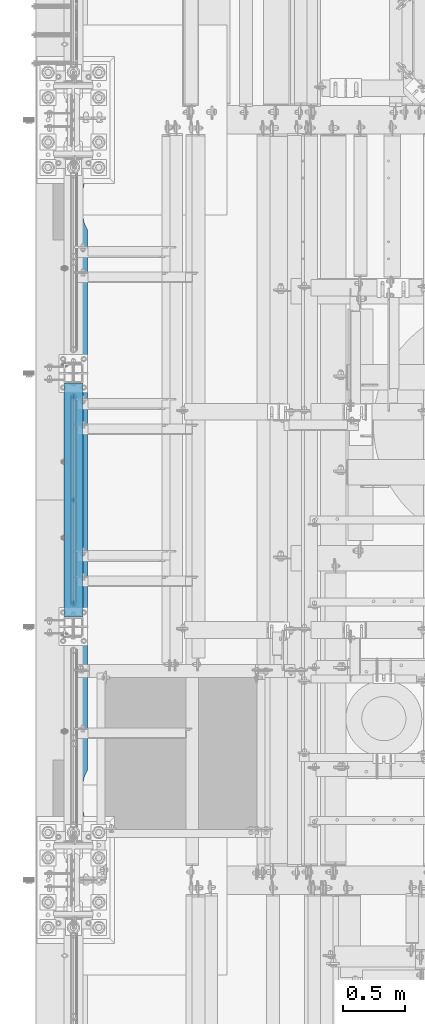
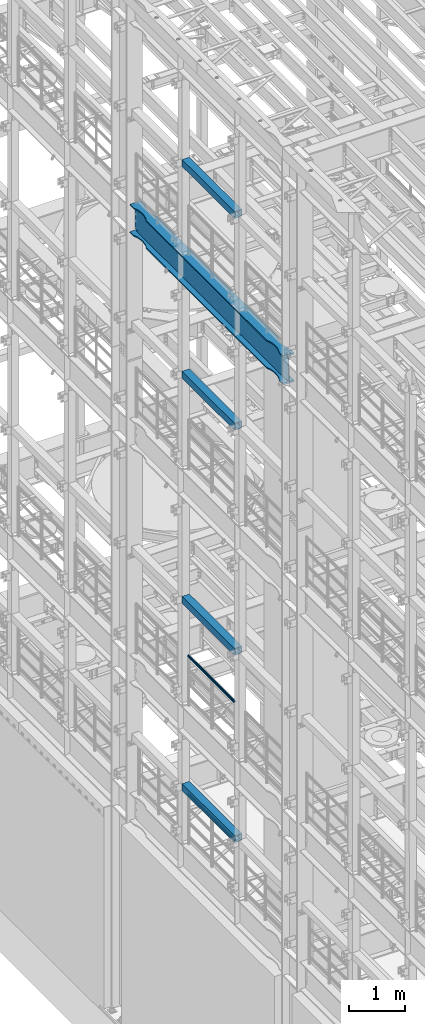
# One storey, part 1020 of 1876: 7 beams, 7 elements without a shape of their own.
"""IFC2X3 building model written with IfcOpenShell, lengths in millimetres."""

from ifc_helpers import new_model, si_unit, frame, origin_with_axes, place, context, subcontext, project, spatial, faceted_brep, material, type_object, element, aggregate, save


model = new_model("IFC2X3")

# Units and contexts
model_context = context("Model", 3, precision=1e-05, world=origin_with_axes())
body_context = subcontext(model_context, "Body", "Model", "MODEL_VIEW")
ifc_project = project(units=[si_unit("LENGTHUNIT", "METRE", prefix="MILLI"), si_unit("AREAUNIT", "SQUARE_METRE"), si_unit("VOLUMEUNIT", "CUBIC_METRE"), si_unit("MASSUNIT", "GRAM", prefix="KILO"), si_unit("TIMEUNIT", "SECOND"), si_unit("PLANEANGLEUNIT", "RADIAN"), si_unit("SOLIDANGLEUNIT", "STERADIAN"), si_unit("THERMODYNAMICTEMPERATUREUNIT", "DEGREE_CELSIUS"), si_unit("LUMINOUSINTENSITYUNIT", "LUMEN")], contexts=[model_context])

# Site, building, storey
site_placement = place(None, origin_with_axes())
site = spatial("IfcSite", under=ifc_project, at=site_placement, CompositionType="ELEMENT")
building_placement = place(site_placement, origin_with_axes())
building = spatial("IfcBuilding", under=site, at=building_placement, Name="Undefined", CompositionType="ELEMENT")
storey_placement = place(building_placement, origin_with_axes())
storey = spatial("IfcBuildingStorey", under=building, at=storey_placement, Name="Undefined", CompositionType="ELEMENT", Elevation=0.0)

# Assembly, beam
assembly_1_placement = place(storey_placement, origin_with_axes())
assembly_1 = element("IfcElementAssembly", 1, at=assembly_1_placement, inside=storey, Name="RAIL", AssemblyPlace="NOTDEFINED", PredefinedType="RIGID_FRAME")
ifc_material_1 = material()
beam_type_1 = type_object("IfcBeamType", Name="PIPE1-1/2SCH40", PredefinedType="NOTDEFINED")
beam_1_placement = place(assembly_1_placement, frame((-1.81898940354586e-12, 3721.1, 9229.725), z_axis=(0.0, 0.0, -1.0), x_axis=(0.0, 1.0, 0.0)))
beam_1 = element("IfcBeam", 2, at=beam_1_placement, type_object=beam_type_1, material=ifc_material_1, Name="RAIL", ObjectType="PIPE1-1/2SCH40", context=body_context, shape_type="Brep", body=[
    faceted_brep([(24.1300000000001, -20.4469999999999, 0.0), (34.3535000000002, -17.7076214311803, 10.2235000000001), (1667.4465, -17.7076214311801, 10.2235000000001), (1677.67, -20.4470000000001, 0.0), (41.8376214311802, -10.2235000000001, 17.7076214311819), (1659.96237856882, -10.2235000000001, 17.7076214311819), (44.5770000000002, 0.0, 20.4470000000001), (1657.223, 0.0, 20.4470000000001), (41.8376214311802, 10.2235000000001, 17.7076214311819), (1659.96237856882, 10.2235000000001, 17.7076214311819), (34.3535000000002, 17.7076214311803, 10.2235000000001), (1667.4465, 17.7076214311801, 10.2235000000001), (24.1300000000001, 20.4469999999999, 0.0), (1677.67, 20.4470000000001, 0.0), (13.9065000000001, 17.7076214311803, -10.2235000000001), (1687.8935, 17.7076214311801, -10.2235000000001), (6.42237856882002, 10.2235000000001, -17.7076214311819), (1695.37762143118, 10.2235000000001, -17.7076214311819), (3.68299999999999, 0.0, -20.4470000000001), (1698.117, 0.0, -20.4470000000001), (6.42237856882002, -10.2235000000001, -17.7076214311819), (1695.37762143118, -10.2235000000001, -17.7076214311819), (13.9065000000001, -17.7076214311803, -10.2235000000001), (1687.8935, -17.7076214311801, -10.2235000000001), (24.1299999999854, -24.1299999999992, 0.0), (12.0650000000064, -20.8971929933177, -12.0649999999987), (1689.735, -20.8971929933186, -12.0649999999987), (1677.67, -24.1300000000001, 0.0), (3.23280700668147, -12.0650000000001, -20.8971929933177), (1698.56719299332, -12.0649999999996, -20.8971929933177), (-1.45519152283669e-11, 0.0, -24.130000000001), (1701.8, 0.0, -24.130000000001), (3.23280700668147, 12.0650000000001, -20.8971929933177), (1698.56719299332, 12.0649999999996, -20.8971929933177), (12.0650000000064, 20.8971929933177, -12.0649999999987), (1689.735, 20.8971929933186, -12.0649999999987), (24.1300000000047, 24.1299999999992, 0.0), (1677.67, 24.1300000000001, 0.0), (36.1949999999997, 20.8971929933184, 12.0649999999987), (1665.605, 20.8971929933186, 12.0649999999987), (45.0271929933187, 12.0650000000001, 20.8971929933177), (1656.77280700668, 12.0649999999996, 20.8971929933177), (48.2600000000002, 0.0, 24.130000000001), (1653.54, 0.0, 24.130000000001), (45.0271929933187, -12.0650000000001, 20.8971929933177), (1656.77280700668, -12.0649999999996, 20.8971929933177), (36.1949999999997, -20.8971929933184, 12.0649999999987), (1665.605, -20.8971929933186, 12.0649999999987)], [[[0, 1, 2, 3]], [[1, 4, 5, 2]], [[4, 6, 7, 5]], [[6, 8, 9, 7]], [[8, 10, 11, 9]], [[10, 12, 13, 11]], [[12, 14, 15, 13]], [[14, 16, 17, 15]], [[16, 18, 19, 17]], [[18, 20, 21, 19]], [[20, 22, 23, 21]], [[22, 0, 3, 23]], [[24, 25, 26, 27]], [[25, 28, 29, 26]], [[28, 30, 31, 29]], [[30, 32, 33, 31]], [[32, 34, 35, 33]], [[34, 36, 37, 35]], [[36, 38, 39, 37]], [[38, 40, 41, 39]], [[40, 42, 43, 41]], [[42, 44, 45, 43]], [[44, 46, 47, 45]], [[46, 24, 27, 47]], [[29, 31, 33, 35, 37, 39, 41, 43, 45, 47, 27, 26], [5, 7, 9, 11, 13, 15, 17, 19, 21, 23, 3, 2]], [[46, 44, 42, 40, 38, 36, 34, 32, 30, 28, 25, 24], [22, 20, 18, 16, 14, 12, 10, 8, 6, 4, 1, 0]]]),
])
aggregate(assembly_1, [beam_1])

assembly_2_placement = place(storey_placement, origin_with_axes())
assembly_2 = element("IfcElementAssembly", 3, at=assembly_2_placement, inside=storey, Name="RAIL", AssemblyPlace="NOTDEFINED", PredefinedType="RIGID_FRAME")
beam_2_placement = place(assembly_2_placement, frame((-1.81898940354586e-12, 3721.1, 6207.125), z_axis=(0.0, 0.0, -1.0), x_axis=(0.0, 1.0, 0.0)))
beam_2 = element("IfcBeam", 4, at=beam_2_placement, type_object=beam_type_1, material=ifc_material_1, Name="RAIL", ObjectType="PIPE1-1/2SCH40", context=body_context, shape_type="Brep", body=[
    faceted_brep([(24.1300000000001, -20.4469999999999, 0.0), (34.3535000000002, -17.7076214311803, 10.2235000000001), (1667.4465, -17.7076214311801, 10.2235000000001), (1677.67, -20.4470000000001, 0.0), (41.8376214311802, -10.2235000000001, 17.7076214311819), (1659.96237856882, -10.2235000000001, 17.7076214311819), (44.5770000000002, 0.0, 20.4470000000001), (1657.223, 0.0, 20.4470000000001), (41.8376214311802, 10.2235000000001, 17.7076214311819), (1659.96237856882, 10.2235000000001, 17.7076214311819), (34.3535000000002, 17.7076214311803, 10.2235000000001), (1667.4465, 17.7076214311801, 10.2235000000001), (24.1300000000001, 20.4469999999999, 0.0), (1677.67, 20.4470000000001, 0.0), (13.9065000000001, 17.7076214311803, -10.2235000000001), (1687.8935, 17.7076214311801, -10.2235000000001), (6.42237856882002, 10.2235000000001, -17.7076214311819), (1695.37762143118, 10.2235000000001, -17.7076214311819), (3.68299999999999, 0.0, -20.4470000000001), (1698.117, 0.0, -20.4470000000001), (6.42237856882002, -10.2235000000001, -17.7076214311819), (1695.37762143118, -10.2235000000001, -17.7076214311819), (13.9065000000001, -17.7076214311803, -10.2235000000001), (1687.8935, -17.7076214311801, -10.2235000000001), (24.1299999999854, -24.1299999999992, 0.0), (12.0650000000064, -20.8971929933177, -12.0649999999987), (1689.735, -20.8971929933186, -12.0649999999987), (1677.67, -24.1300000000001, 0.0), (3.23280700668147, -12.0650000000001, -20.8971929933177), (1698.56719299332, -12.0649999999996, -20.8971929933177), (-1.45519152283669e-11, 0.0, -24.130000000001), (1701.8, 0.0, -24.130000000001), (3.23280700668147, 12.0650000000001, -20.8971929933177), (1698.56719299332, 12.0649999999996, -20.8971929933177), (12.0650000000064, 20.8971929933177, -12.0649999999987), (1689.735, 20.8971929933186, -12.0649999999987), (24.1300000000047, 24.1299999999992, 0.0), (1677.67, 24.1300000000001, 0.0), (36.1949999999997, 20.8971929933184, 12.0649999999987), (1665.605, 20.8971929933186, 12.0649999999987), (45.0271929933187, 12.0650000000001, 20.8971929933177), (1656.77280700668, 12.0649999999996, 20.8971929933177), (48.2600000000002, 0.0, 24.130000000001), (1653.54, 0.0, 24.130000000001), (45.0271929933187, -12.0650000000001, 20.8971929933177), (1656.77280700668, -12.0649999999996, 20.8971929933177), (36.1949999999997, -20.8971929933184, 12.0649999999987), (1665.605, -20.8971929933186, 12.0649999999987)], [[[0, 1, 2, 3]], [[1, 4, 5, 2]], [[4, 6, 7, 5]], [[6, 8, 9, 7]], [[8, 10, 11, 9]], [[10, 12, 13, 11]], [[12, 14, 15, 13]], [[14, 16, 17, 15]], [[16, 18, 19, 17]], [[18, 20, 21, 19]], [[20, 22, 23, 21]], [[22, 0, 3, 23]], [[24, 25, 26, 27]], [[25, 28, 29, 26]], [[28, 30, 31, 29]], [[30, 32, 33, 31]], [[32, 34, 35, 33]], [[34, 36, 37, 35]], [[36, 38, 39, 37]], [[38, 40, 41, 39]], [[40, 42, 43, 41]], [[42, 44, 45, 43]], [[44, 46, 47, 45]], [[46, 24, 27, 47]], [[29, 31, 33, 35, 37, 39, 41, 43, 45, 47, 27, 26], [5, 7, 9, 11, 13, 15, 17, 19, 21, 23, 3, 2]], [[46, 44, 42, 40, 38, 36, 34, 32, 30, 28, 25, 24], [22, 20, 18, 16, 14, 12, 10, 8, 6, 4, 1, 0]]]),
])
aggregate(assembly_2, [beam_2])

assembly_3_placement = place(storey_placement, origin_with_axes())
assembly_3 = element("IfcElementAssembly", 5, at=assembly_3_placement, inside=storey, Name="BEAM", AssemblyPlace="NOTDEFINED", PredefinedType="RIGID_FRAME")
ifc_material_2 = material()
beam_type_2 = type_object("IfcBeamType", Name="HSS6X6X3/8", PredefinedType="NOTDEFINED")
beam_3_placement = place(assembly_3_placement, frame((0.0, 3556.0, 19958.05), z_axis=(-1.0, 0.0, 0.0), x_axis=(0.0, 1.0, 0.0)))
beam_3 = element("IfcBeam", 6, at=beam_3_placement, type_object=beam_type_2, material=ifc_material_2, Name="BEAM", ObjectType="HSS6X6X3/8", context=body_context, shape_type="Brep", body=[
    faceted_brep([(76.2000000000007, 66.6749999999993, -66.6750000000002), (76.2000000000007, -66.6749999999993, -66.6750000000002), (1955.8, -66.6749999999993, -66.675), (1955.8, 66.6749999999993, -66.675), (76.2000000000007, -66.6749999999993, 66.6750000000002), (1955.8, -66.6749999999993, 66.675), (76.2000000000007, 66.6749999999993, 66.6750000000002), (1955.8, 66.6749999999993, 66.675), (76.2000000000007, 76.2000000000007, -76.1999999999998), (76.2000000000007, 76.2000000000007, 76.1999999999998), (1955.8, 76.2000000000007, 76.2), (1955.8, 76.2000000000007, -76.2), (76.2000000000007, -76.2000000000007, 76.1999999999998), (1955.8, -76.2000000000007, 76.2), (76.2000000000007, -76.2000000000007, -76.1999999999998), (1955.8, -76.2000000000007, -76.2)], [[[0, 1, 2, 3]], [[1, 4, 5, 2]], [[4, 6, 7, 5]], [[6, 0, 3, 7]], [[8, 9, 10, 11]], [[9, 12, 13, 10]], [[12, 14, 15, 13]], [[14, 8, 11, 15]], [[13, 15, 11, 10], [5, 7, 3, 2]], [[14, 12, 9, 8], [6, 4, 1, 0]]]),
])
aggregate(assembly_3, [beam_3])

assembly_4_placement = place(storey_placement, origin_with_axes())
assembly_4 = element("IfcElementAssembly", 7, at=assembly_4_placement, inside=storey, Name="BEAM", AssemblyPlace="NOTDEFINED", PredefinedType="RIGID_FRAME")
beam_4_placement = place(assembly_4_placement, frame((0.0, 3556.0, 15335.25), z_axis=(-1.0, 0.0, 0.0), x_axis=(0.0, 1.0, 0.0)))
beam_4 = element("IfcBeam", 8, at=beam_4_placement, type_object=beam_type_2, material=ifc_material_2, Name="BEAM", ObjectType="HSS6X6X3/8", context=body_context, shape_type="Brep", body=[
    faceted_brep([(76.2000000000007, 66.6749999999993, -66.6750000000002), (76.2000000000007, -66.6749999999993, -66.6750000000002), (1955.8, -66.6749999999993, -66.675), (1955.8, 66.6749999999993, -66.675), (76.2000000000007, -66.6749999999993, 66.6750000000002), (1955.8, -66.6749999999993, 66.675), (76.2000000000007, 66.6749999999993, 66.6750000000002), (1955.8, 66.6749999999993, 66.675), (76.2000000000007, 76.2000000000007, -76.1999999999998), (76.2000000000007, 76.2000000000007, 76.1999999999998), (1955.8, 76.2000000000007, 76.2), (1955.8, 76.2000000000007, -76.2), (76.2000000000007, -76.2000000000007, 76.1999999999998), (1955.8, -76.2000000000007, 76.2), (76.2000000000007, -76.2000000000007, -76.1999999999998), (1955.8, -76.2000000000007, -76.2)], [[[0, 1, 2, 3]], [[1, 4, 5, 2]], [[4, 6, 7, 5]], [[6, 0, 3, 7]], [[8, 9, 10, 11]], [[9, 12, 13, 10]], [[12, 14, 15, 13]], [[14, 8, 11, 15]], [[13, 15, 11, 10], [5, 7, 3, 2]], [[14, 12, 9, 8], [6, 4, 1, 0]]]),
])
aggregate(assembly_4, [beam_4])

assembly_5_placement = place(storey_placement, origin_with_axes())
assembly_5 = element("IfcElementAssembly", 9, at=assembly_5_placement, inside=storey, Name="BEAM", AssemblyPlace="NOTDEFINED", PredefinedType="RIGID_FRAME")
beam_5_placement = place(assembly_5_placement, frame((0.0, 3556.0, 10420.35), z_axis=(-1.0, 0.0, 0.0), x_axis=(0.0, 1.0, 0.0)))
beam_5 = element("IfcBeam", 10, at=beam_5_placement, type_object=beam_type_2, material=ifc_material_2, Name="BEAM", ObjectType="HSS6X6X3/8", context=body_context, shape_type="Brep", body=[
    faceted_brep([(76.2000000000007, 66.6749999999993, -66.6750000000002), (76.2000000000007, -66.6749999999993, -66.6750000000002), (1955.8, -66.6749999999993, -66.675), (1955.8, 66.6749999999993, -66.675), (76.2000000000007, -66.6749999999993, 66.6750000000002), (1955.8, -66.6749999999993, 66.675), (76.2000000000007, 66.6749999999993, 66.6750000000002), (1955.8, 66.6749999999993, 66.675), (76.2000000000007, 76.2000000000007, -76.1999999999998), (76.2000000000007, 76.2000000000007, 76.1999999999998), (1955.8, 76.2000000000007, 76.2), (1955.8, 76.2000000000007, -76.2), (76.2000000000007, -76.2000000000007, 76.1999999999998), (1955.8, -76.2000000000007, 76.2), (76.2000000000007, -76.2000000000007, -76.1999999999998), (1955.8, -76.2000000000007, -76.2)], [[[0, 1, 2, 3]], [[1, 4, 5, 2]], [[4, 6, 7, 5]], [[6, 0, 3, 7]], [[8, 9, 10, 11]], [[9, 12, 13, 10]], [[12, 14, 15, 13]], [[14, 8, 11, 15]], [[13, 15, 11, 10], [5, 7, 3, 2]], [[14, 12, 9, 8], [6, 4, 1, 0]]]),
])
aggregate(assembly_5, [beam_5])

assembly_6_placement = place(storey_placement, origin_with_axes())
assembly_6 = element("IfcElementAssembly", 11, at=assembly_6_placement, inside=storey, Name="BEAM", AssemblyPlace="NOTDEFINED", PredefinedType="RIGID_FRAME")
beam_6_placement = place(assembly_6_placement, frame((0.0, 3556.0, 6330.95), z_axis=(-1.0, 0.0, 0.0), x_axis=(0.0, 1.0, 0.0)))
beam_6 = element("IfcBeam", 12, at=beam_6_placement, type_object=beam_type_2, material=ifc_material_2, Name="BEAM", ObjectType="HSS6X6X3/8", context=body_context, shape_type="Brep", body=[
    faceted_brep([(76.2000000000007, 66.6749999999993, -66.6750000000002), (76.2000000000007, -66.6749999999993, -66.6750000000002), (1955.8, -66.6749999999993, -66.675), (1955.8, 66.6749999999993, -66.675), (76.2000000000007, -66.6749999999993, 66.6750000000002), (1955.8, -66.6749999999993, 66.675), (76.2000000000007, 66.6749999999993, 66.6750000000002), (1955.8, 66.6749999999993, 66.675), (76.2000000000007, 76.2000000000007, -76.1999999999998), (76.2000000000007, 76.2000000000007, 76.1999999999998), (1955.8, 76.2000000000007, 76.2), (1955.8, 76.2000000000007, -76.2), (76.2000000000007, -76.2000000000007, 76.1999999999998), (1955.8, -76.2000000000007, 76.2), (76.2000000000007, -76.2000000000007, -76.1999999999998), (1955.8, -76.2000000000007, -76.2)], [[[0, 1, 2, 3]], [[1, 4, 5, 2]], [[4, 6, 7, 5]], [[6, 0, 3, 7]], [[8, 9, 10, 11]], [[9, 12, 13, 10]], [[12, 14, 15, 13]], [[14, 8, 11, 15]], [[13, 15, 11, 10], [5, 7, 3, 2]], [[14, 12, 9, 8], [6, 4, 1, 0]]]),
])
aggregate(assembly_6, [beam_6])

assembly_7_placement = place(storey_placement, origin_with_axes())
assembly_7 = element("IfcElementAssembly", 13, at=assembly_7_placement, inside=storey, Name="BEAM", AssemblyPlace="NOTDEFINED", PredefinedType="RIGID_FRAME")
ifc_material_3 = material(Name="STEEL/A992")
beam_type_3 = type_object("IfcBeamType", Name="W24X103", PredefinedType="NOTDEFINED")
beam_7_placement = place(assembly_7_placement, frame((0.0, 1524.0, 17672.05), z_axis=(0.0, 0.0, 1.0), x_axis=(0.0, 1.0, 0.0)))
beam_7 = element("IfcBeam", 14, at=beam_7_placement, type_object=beam_type_3, material=ifc_material_3, Name="BEAM", ObjectType="W24X103", context=body_context, shape_type="Brep", body=[
    faceted_brep([(306.3875, 7.14375, -250.825000000001), (298.45, -7.14375, -250.825000000001), (298.45, -7.14375, 250.825000000001), (306.3875, 7.14375, 250.825000000001), (5789.6125, 7.14375, 250.825000000001), (5797.55, -7.14375, 250.825000000001), (5797.55, -7.14375, -250.825000000001), (5789.6125, 7.14375, -250.825000000001), (5641.97500876196, 114.299992330618, -285.75), (5641.97500876196, 114.3, -311.150000000001), (5592.87586146151, 88.8999957361821, -311.150000000001), (5592.87586146151, 88.8999957361821, -285.75), (5510.43685211057, 69.8863924058523, -311.150000000001), (5510.43685211057, 69.8863924058523, -285.75), (5426.0750039875, 63.5000040971918, -311.150000000001), (5426.0750039875, 63.5000040971918, -285.75), (5341.71315599965, 69.8863941921136, -311.150000000001), (5341.71315599965, 69.8863941921136, -285.75), (5259.2741470513, 88.8999992679901, -311.150000000001), (5259.2741470513, 88.8999992679901, -285.75), (5210.175, 114.3, -311.150000000001), (5210.175, 114.3, -285.75), (885.825008761703, 114.3, -311.150000000001), (885.825008761703, 114.299990374483, -285.75), (836.72586171043, 88.899989642473, -311.150000000001), (836.72586171043, 88.899989642473, -285.75), (754.286852762112, 69.8863845665965, -311.150000000001), (754.286852762112, 69.8863845665965, -285.75), (669.925004774302, 63.4999944716747, -311.150000000001), (669.925004774302, 63.4999944716747, -285.75), (585.563156651265, 69.8863827803352, -311.150000000001), (585.563156651265, 69.8863827803352, -285.75), (503.124147300347, 88.8999861106649, -311.150000000001), (503.124147300347, 88.8999861106649, -285.75), (454.024999999921, 114.3, -311.150000000001), (454.024999999921, 114.3, -285.75), (298.45, 114.3, -311.150000000001), (313.11459905754, 114.3, -285.75), (5641.97500876196, -114.299992330618, -285.75), (5592.87586146151, -88.8999957361821, -285.75), (5592.87586146151, -88.8999957361821, -311.150000000001), (5641.97500876196, -114.3, -311.150000000001), (5510.43685211057, -69.8863924058523, -285.75), (5510.43685211057, -69.8863924058523, -311.150000000001), (5426.0750039875, -63.5000040971918, -285.75), (5426.0750039875, -63.5000040971918, -311.150000000001), (5341.71315599965, -69.8863941921136, -285.75), (5341.71315599965, -69.8863941921136, -311.150000000001), (5259.2741470513, -88.8999992679901, -285.75), (5259.2741470513, -88.8999992679901, -311.150000000001), (5210.175, -114.3, -285.75), (5210.175, -114.3, -311.150000000001), (885.825008761703, -114.300009625517, -285.75), (885.825008761703, -114.3, -311.150000000001), (836.72586171043, -88.9000088935072, -285.75), (836.72586171043, -88.9000088935072, -311.150000000001), (754.286852762112, -69.8864038176307, -285.75), (754.286852762112, -69.8864038176307, -311.150000000001), (669.925004774302, -63.5000137227089, -285.75), (669.925004774302, -63.5000137227089, -311.150000000001), (585.563156651265, -69.8864020313695, -285.75), (585.563156651265, -69.8864020313695, -311.150000000001), (503.124147300347, -88.9000053616992, -285.75), (503.124147300347, -88.9000053616992, -311.150000000001), (454.024999999921, -114.3, -285.75), (454.024999999921, -114.3, -311.150000000001), (313.11459905754, -114.3, -285.75), (298.45, -114.3, -311.150000000001), (313.343799385621, -7.14375000000018, -285.35299987793), (313.343799385621, 7.14375000000018, -285.35299987793), (313.114599057541, 7.14375000000018, -285.75), (313.114599057541, -7.14375000000018, -285.75), (346.909996826172, -7.14375000000018, -285.35299987793), (346.909996826172, 7.14375000000018, -285.35299987793), (382.382251149282, -7.14375000000018, -269.000062630286), (382.382251149282, 7.14375000000018, -269.000062630286), (386.272459055476, -7.14375000000018, -265.703842989446), (386.272459055476, 7.14375000000018, -265.703842989446), (387.905124802588, -7.14375000000018, -260.873399528195), (387.905124802588, 7.14375000000018, -260.873399528195), (386.81238362386, -7.14375000000018, -255.89296800167), (386.81238362386, 7.14375000000018, -255.89296800167), (383.307376832887, -7.14375000000018, -252.189765486371), (383.307376832887, 7.14375000000018, -252.189765486371), (378.39451650093, -7.14375000000018, -250.825000000001), (378.39451650093, 7.14375000000018, -250.825000000001), (377.559514535493, -7.14375000000018, 250.825000000001), (377.559514535493, 7.14375000000018, 250.825000000001), (382.472374804242, -7.14375000000018, 252.189765448315), (382.472374804242, 7.14375000000018, 252.189765448315), (385.977381589376, -7.14375000000018, 255.892967871263), (385.977381589376, 7.14375000000018, 255.892967871263), (387.070122849314, -7.14375000000018, 260.873399307191), (387.070122849314, 7.14375000000018, 260.873399307191), (385.437457255921, -7.14375000000018, 265.703842745359), (385.437457255921, 7.14375000000018, 265.703842745359), (381.547249518856, -7.14375000000018, 269.000062475843), (381.547249518856, 7.14375000000018, 269.000062475843), (346.074998474121, -7.14375000000018, 285.35299987793), (346.074998474121, 7.14375000000018, 285.35299987793), (298.45, -7.14375000000018, 285.35299987793), (298.45, 7.14375000000018, 285.35299987793), (454.024999999921, 114.3, 311.150000000001), (454.024999999921, 114.3, 285.75), (298.45, 114.3, 285.75), (313.114586308271, 114.3, 311.150000000001), (503.124147300347, 88.8999861106649, 311.150000000001), (503.124147300347, 88.8999861106649, 285.75), (585.563156651265, 69.8863827803352, 311.150000000001), (585.563156651265, 69.8863827803352, 285.75), (669.925004774302, 63.4999944716747, 311.150000000001), (669.925004774302, 63.4999944716747, 285.75), (754.286852762112, 69.8863845665965, 311.150000000001), (754.286852762112, 69.8863845665965, 285.75), (836.72586171043, 88.899989642473, 311.150000000001), (836.72586171043, 88.899989642473, 285.75), (885.825008761703, 114.299990374483, 311.150000000001), (885.825008761703, 114.3, 285.75), (5210.175, 114.3, 311.150000000001), (5210.175, 114.3, 285.75), (5259.2741470513, 88.8999992679901, 311.150000000001), (5259.2741470513, 88.8999992679901, 285.75), (5341.71315599965, 69.8863941921136, 311.150000000001), (5341.71315599965, 69.8863941921136, 285.75), (5426.0750039875, 63.5000040971918, 311.150000000001), (5426.0750039875, 63.5000040971918, 285.75), (5510.43685211057, 69.8863924058523, 311.150000000001), (5510.43685211057, 69.8863924058523, 285.75), (5592.87586146151, 88.8999957361821, 311.150000000001), (5592.87586146151, 88.8999957361821, 285.75), (5641.97500876196, 114.299992330618, 311.150000000001), (5641.97500876196, 114.3, 285.75), (5782.88541369173, 114.29999927708, 311.150000000001), (5797.55, 114.3, 285.75), (298.45, 7.14375000000018, 285.75), (5797.55, 7.14375000000018, 285.75), (5797.55, -7.14375000000018, 285.35299987793), (5797.55, 7.14375000000018, 285.35299987793), (5797.55, -7.14375000000018, 285.75), (5749.92500152588, -7.14375000000018, 285.35299987793), (5749.92500152588, 7.14375000000018, 285.35299987793), (5714.45275048114, -7.14375000000018, 269.000062475843), (5714.45275048114, 7.14375000000018, 269.000062475843), (5710.56254274408, -7.14375000000018, 265.703842745359), (5710.56254274408, 7.14375000000018, 265.703842745359), (5708.92987715069, -7.14375000000018, 260.873399307191), (5708.92987715069, 7.14375000000018, 260.873399307191), (5710.02261841062, -7.14375000000018, 255.892967871263), (5710.02261841062, 7.14375000000018, 255.892967871263), (5713.52762519576, -7.14375000000018, 252.189765448315), (5713.52762519576, 7.14375000000018, 252.189765448315), (5718.44048546451, -7.14375000000018, 250.825000000001), (5718.44048546451, 7.14375000000018, 250.825000000001), (5717.60548349907, -7.14375000000018, -250.825000000001), (5717.60548349907, 7.14375000000018, -250.825000000001), (5712.69262316711, -7.14375000000018, -252.189765486371), (5712.69262316711, 7.14375000000018, -252.189765486371), (5709.18761637614, -7.14375000000018, -255.89296800167), (5709.18761637614, 7.14375000000018, -255.89296800167), (5708.09487519741, -7.14375000000018, -260.873399528195), (5708.09487519741, 7.14375000000018, -260.873399528195), (5709.72754094452, -7.14375000000018, -265.703842989446), (5709.72754094452, 7.14375000000018, -265.703842989446), (5713.61774885072, -7.14375000000018, -269.000062630286), (5713.61774885072, 7.14375000000018, -269.000062630286), (5749.09000317383, -7.14375000000018, -285.35299987793), (5749.09000317383, 7.14375000000018, -285.35299987793), (5782.65620061438, -7.14375000000018, -285.35299987793), (5782.65620061438, 7.14375000000018, -285.35299987793), (5782.88540094246, 7.14375000000018, -285.75), (5782.88540094246, 114.299999277079, -285.75), (5797.55, 114.3, -311.150000000001), (5797.55, -114.3, -311.150000000001), (5782.88540094246, -114.299999277079, -285.75), (5782.88540094246, -7.14375000000018, -285.75), (298.45, -7.14375000000018, 285.75), (313.114586308271, -114.3, 311.150000000001), (298.45, -114.3, 285.75), (454.024999999921, -114.3, 285.75), (454.024999999921, -114.3, 311.150000000001), (503.124147300347, -88.9000053616992, 285.75), (503.124147300347, -88.9000053616992, 311.150000000001), (585.563156651265, -69.8864020313695, 285.75), (585.563156651265, -69.8864020313695, 311.150000000001), (669.925004774302, -63.5000137227089, 285.75), (669.925004774302, -63.5000137227089, 311.150000000001), (754.286852762112, -69.8864038176307, 285.75), (754.286852762112, -69.8864038176307, 311.150000000001), (836.72586171043, -88.9000088935072, 285.75), (836.72586171043, -88.9000088935072, 311.150000000001), (885.825008761703, -114.300009625517, 311.150000000001), (885.825008761703, -114.3, 285.75), (5210.175, -114.3, 285.75), (5210.175, -114.3, 311.150000000001), (5259.2741470513, -88.8999992679901, 285.75), (5259.2741470513, -88.8999992679901, 311.150000000001), (5341.71315599965, -69.8863941921136, 285.75), (5341.71315599965, -69.8863941921136, 311.150000000001), (5426.0750039875, -63.5000040971918, 285.75), (5426.0750039875, -63.5000040971918, 311.150000000001), (5510.43685211057, -69.8863924058523, 285.75), (5510.43685211057, -69.8863924058523, 311.150000000001), (5592.87586146151, -88.8999957361821, 285.75), (5592.87586146151, -88.8999957361821, 311.150000000001), (5641.97500876196, -114.299992330618, 311.150000000001), (5641.97500876196, -114.3, 285.75), (5797.55, -114.3, 285.75), (5782.88541369173, -114.29999927708, 311.150000000001)], [[[0, 1, 2, 3]], [[4, 5, 6, 7]], [[8, 9, 10, 11]], [[11, 10, 12, 13]], [[13, 12, 14, 15]], [[15, 14, 16, 17]], [[17, 16, 18, 19]], [[19, 18, 20, 21]], [[21, 20, 22, 23]], [[23, 22, 24, 25]], [[25, 24, 26, 27]], [[27, 26, 28, 29]], [[29, 28, 30, 31]], [[31, 30, 32, 33]], [[33, 32, 34, 35]], [[35, 34, 36, 37]], [[38, 39, 40, 41]], [[42, 43, 40, 39]], [[44, 45, 43, 42]], [[46, 47, 45, 44]], [[48, 49, 47, 46]], [[50, 51, 49, 48]], [[51, 50, 52, 53]], [[52, 54, 55, 53]], [[56, 57, 55, 54]], [[58, 59, 57, 56]], [[60, 61, 59, 58]], [[62, 63, 61, 60]], [[64, 65, 63, 62]], [[65, 64, 66, 67]], [[68, 69, 70, 37, 36, 67, 66, 71]], [[72, 73, 69, 68]], [[74, 75, 73, 72]], [[76, 77, 75, 74]], [[78, 79, 77, 76]], [[80, 81, 79, 78]], [[82, 83, 81, 80]], [[84, 85, 83, 82]], [[85, 84, 1, 0]], [[86, 87, 3, 2]], [[88, 89, 87, 86]], [[90, 91, 89, 88]], [[92, 93, 91, 90]], [[94, 95, 93, 92]], [[96, 97, 95, 94]], [[98, 99, 97, 96]], [[99, 98, 100, 101]], [[102, 103, 104, 105]], [[106, 107, 103, 102]], [[108, 109, 107, 106]], [[110, 111, 109, 108]], [[112, 113, 111, 110]], [[114, 115, 113, 112]], [[116, 117, 115, 114]], [[118, 119, 117, 116]], [[120, 121, 119, 118]], [[122, 123, 121, 120]], [[124, 125, 123, 122]], [[126, 127, 125, 124]], [[128, 129, 127, 126]], [[130, 131, 129, 128]], [[131, 130, 132, 133]], [[134, 104, 103, 107, 109, 111, 113, 115, 117, 119, 121, 123, 125, 127, 129, 131, 133, 135]], [[136, 137, 135, 138]], [[139, 140, 137, 136]], [[141, 142, 140, 139]], [[143, 144, 142, 141]], [[145, 146, 144, 143]], [[147, 148, 146, 145]], [[149, 150, 148, 147]], [[151, 152, 150, 149]], [[152, 151, 5, 4]], [[153, 154, 7, 6]], [[155, 156, 154, 153]], [[157, 158, 156, 155]], [[159, 160, 158, 157]], [[161, 162, 160, 159]], [[163, 164, 162, 161]], [[165, 166, 164, 163]], [[166, 165, 167, 168]], [[87, 89, 91, 93, 95, 97, 99, 101, 134, 135, 137, 140, 142, 144, 146, 148, 150, 152, 4, 7, 154, 156, 158, 160, 162, 164, 166, 168, 169, 70, 69, 73, 75, 77, 79, 81, 83, 85, 0, 3]], [[8, 11, 13, 15, 17, 19, 21, 23, 25, 27, 29, 31, 33, 35, 37, 70, 169, 170]], [[9, 8, 170, 171]], [[41, 40, 43, 45, 47, 49, 51, 53, 55, 57, 59, 61, 63, 65, 67, 36, 34, 32, 30, 28, 26, 24, 22, 20, 18, 16, 14, 12, 10, 9, 171, 172]], [[38, 41, 172, 173]], [[71, 66, 64, 62, 60, 58, 56, 54, 52, 50, 48, 46, 44, 42, 39, 38, 173, 174]], [[172, 171, 170, 169, 168, 167, 174, 173]], [[165, 163, 161, 159, 157, 155, 153, 6, 5, 151, 149, 147, 145, 143, 141, 139, 136, 138, 175, 100, 98, 96, 94, 92, 90, 88, 86, 2, 1, 84, 82, 80, 78, 76, 74, 72, 68, 71, 174, 167]], [[101, 100, 175, 134]], [[176, 105, 104, 134, 175, 177]], [[178, 179, 176, 177]], [[179, 178, 180, 181]], [[181, 180, 182, 183]], [[183, 182, 184, 185]], [[185, 184, 186, 187]], [[187, 186, 188, 189]], [[190, 189, 188, 191]], [[192, 193, 190, 191]], [[193, 192, 194, 195]], [[195, 194, 196, 197]], [[197, 196, 198, 199]], [[199, 198, 200, 201]], [[201, 200, 202, 203]], [[204, 205, 206, 207]], [[130, 128, 126, 124, 122, 120, 118, 116, 114, 112, 110, 108, 106, 102, 105, 176, 179, 181, 183, 185, 187, 189, 190, 193, 195, 197, 199, 201, 203, 204, 207, 132]], [[206, 138, 135, 133, 132, 207]], [[205, 202, 200, 198, 196, 194, 192, 191, 188, 186, 184, 182, 180, 178, 177, 175, 138, 206]], [[204, 203, 202, 205]]]),
])
aggregate(assembly_7, [beam_7])

save(model, "model.ifc")
